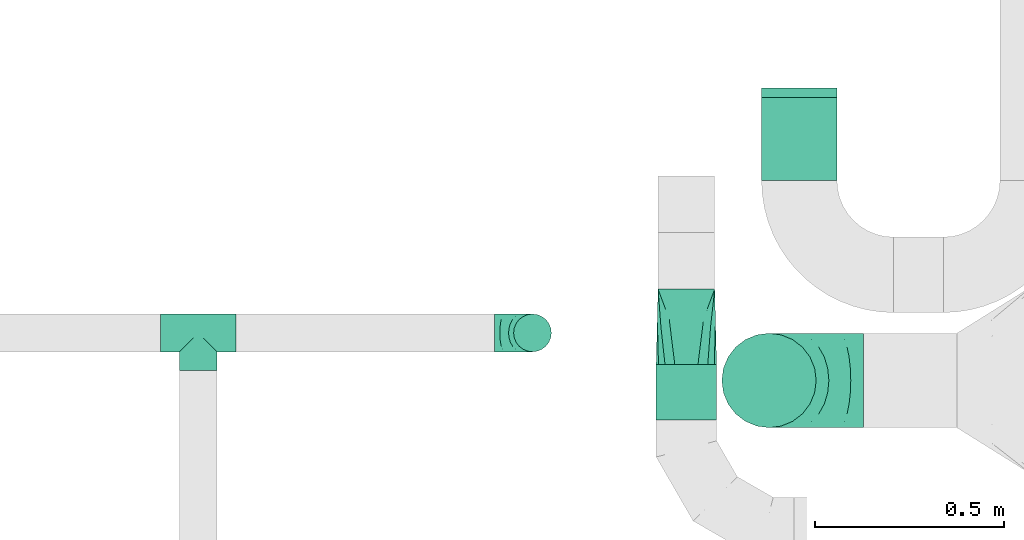
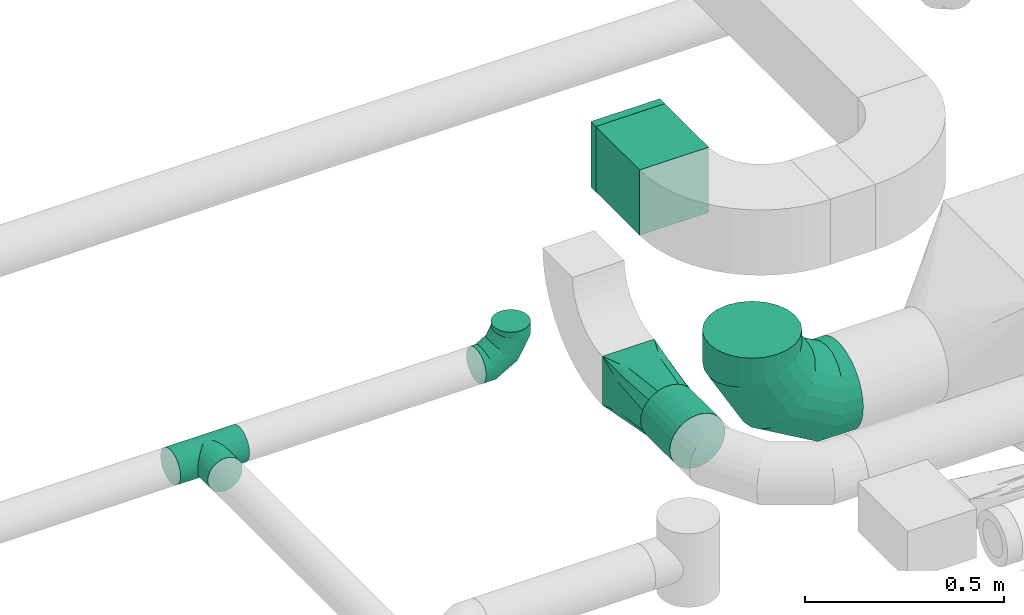
# One storey, part 70 of 92: 5 flow fittings, 2 flow segments.
"""IFC2X3 building model written with IfcOpenShell, lengths in millimetres."""

from ifc_helpers import new_model, entity, si_unit, converted_unit, derived_unit, direction, frame, origin, origin_2d_with_axis, place, context, subcontext, project, spatial, rectangle, circle, extrude, faceted_brep, source, transform, mapped, material, type_object, type_shapes, element, save


model = new_model("IFC2X3")

# Units and contexts
model_context = context("Model", 3, precision=0.01, world=origin(), true_north=direction((6.12303176911189e-17, 1.0)))
body_context = subcontext(model_context, "Body", "Model", "MODEL_VIEW")
ifc_project = project(units=[si_unit("LENGTHUNIT", "METRE", prefix="MILLI"), si_unit("AREAUNIT", "SQUARE_METRE"), si_unit("VOLUMEUNIT", "CUBIC_METRE"), converted_unit("PLANEANGLEUNIT", "DEGREE", entity("IfcRatioMeasure", 0.0174532925199433), si_unit("PLANEANGLEUNIT", "RADIAN"), dimensions=[0, 0, 0, 0, 0, 0, 0]), si_unit("MASSUNIT", "GRAM", prefix="KILO"), derived_unit("MASSDENSITYUNIT", [(si_unit("MASSUNIT", "GRAM", prefix="KILO"), 1), (si_unit("LENGTHUNIT", "METRE"), -3)]), derived_unit("MOMENTOFINERTIAUNIT", [(si_unit("LENGTHUNIT", "METRE"), 4)]), si_unit("TIMEUNIT", "SECOND"), si_unit("FREQUENCYUNIT", "HERTZ"), si_unit("THERMODYNAMICTEMPERATUREUNIT", "DEGREE_CELSIUS"), derived_unit("THERMALTRANSMITTANCEUNIT", [(si_unit("MASSUNIT", "GRAM", prefix="KILO"), 1), (si_unit("THERMODYNAMICTEMPERATUREUNIT", "KELVIN"), -1), (si_unit("TIMEUNIT", "SECOND"), -3)]), derived_unit("VOLUMETRICFLOWRATEUNIT", [(si_unit("LENGTHUNIT", "METRE"), 3), (si_unit("TIMEUNIT", "SECOND"), -1)]), derived_unit("MASSFLOWRATEUNIT", [(si_unit("MASSUNIT", "GRAM", prefix="KILO"), 1), (si_unit("TIMEUNIT", "SECOND"), -1)]), derived_unit("ROTATIONALFREQUENCYUNIT", [(si_unit("TIMEUNIT", "SECOND"), -1)]), si_unit("ELECTRICCURRENTUNIT", "AMPERE"), si_unit("ELECTRICVOLTAGEUNIT", "VOLT"), si_unit("POWERUNIT", "WATT"), si_unit("FORCEUNIT", "NEWTON", prefix="KILO"), si_unit("ILLUMINANCEUNIT", "LUX"), si_unit("LUMINOUSFLUXUNIT", "LUMEN"), si_unit("LUMINOUSINTENSITYUNIT", "CANDELA"), derived_unit("USERDEFINED", [(si_unit("MASSUNIT", "GRAM", prefix="KILO"), -1), (si_unit("LENGTHUNIT", "METRE"), -2), (si_unit("TIMEUNIT", "SECOND"), 3), (si_unit("LUMINOUSFLUXUNIT", "LUMEN"), 1)]), derived_unit("LINEARVELOCITYUNIT", [(si_unit("LENGTHUNIT", "METRE"), 1), (si_unit("TIMEUNIT", "SECOND"), -1)]), si_unit("PRESSUREUNIT", "PASCAL"), derived_unit("USERDEFINED", [(si_unit("LENGTHUNIT", "METRE"), -2), (si_unit("MASSUNIT", "GRAM", prefix="KILO"), 1), (si_unit("TIMEUNIT", "SECOND"), -2)]), derived_unit("LINEARFORCEUNIT", [(si_unit("MASSUNIT", "GRAM", prefix="KILO"), 1), (si_unit("LENGTHUNIT", "METRE"), 1), (si_unit("TIMEUNIT", "SECOND"), -2), (si_unit("LENGTHUNIT", "METRE"), -1)]), derived_unit("PLANARFORCEUNIT", [(si_unit("MASSUNIT", "GRAM", prefix="KILO"), 1), (si_unit("LENGTHUNIT", "METRE"), 1), (si_unit("TIMEUNIT", "SECOND"), -2), (si_unit("LENGTHUNIT", "METRE"), -2)])], contexts=[model_context])

# Site, building, storey
site_placement = place(None, origin())
site = spatial("IfcSite", under=ifc_project, at=site_placement, CompositionType="ELEMENT")
building_placement = place(site_placement, origin())
building = spatial("IfcBuilding", under=site, at=building_placement, CompositionType="ELEMENT")
storey_placement = place(building_placement, frame((0.0, 0.0, 4200.0)))
storey = spatial("IfcBuildingStorey", under=building, at=storey_placement, CompositionType="ELEMENT", Elevation=4200.0)

# Flow segments
duct_segment_type_1 = type_object("IfcDuctSegmentType", PredefinedType="NOTDEFINED")
flow_segment_1_placement = place(storey_placement, frame((59449.99, 13023.45, 3224.59)))
element("IfcFlowSegment", 1, at=flow_segment_1_placement, inside=storey, type_object=duct_segment_type_1, context=body_context, shape_type="SweptSolid", body=[
    extrude(rectangle(XDim=220.000000000004, YDim=199.999999999998, at=origin_2d_with_axis()), frame((100.0, 110.0, 0.0), z_axis=(0.0, 0.0, 1.0), x_axis=(0.0, 1.0, 0.0)), (0.0, 0.0, 1.0), 200.0),
])
duct_segment_type_2 = type_object("IfcDuctSegmentType", PredefinedType="NOTDEFINED")
flow_segment_2_placement = place(storey_placement, frame((59169.54, 12388.83, 2968.4)))
element("IfcFlowSegment", 2, at=flow_segment_2_placement, inside=storey, type_object=duct_segment_type_2, context=body_context, shape_type="SweptSolid", body=[
    extrude(circle(Radius=80.0, at=origin_2d_with_axis()), frame((81.6, 0.0, 81.6), z_axis=(0.0, 1.0, 0.0), x_axis=(-1.0, 0.0, 0.0)), (0.0, 0.0, 1.0), 146.751249421512),
])

# Flow fittings
ifc_material = material()
duct_fitting_type_1 = type_object("IfcDuctFittingType", PredefinedType="NOTDEFINED", material=ifc_material)
shared_shape_1 = source(origin(), body_context, "Body", "SweptSolid", [
    extrude(rectangle(XDim=24.9999999999999, YDim=200.0, at=origin_2d_with_axis()), frame((12.5, 0.0, -100.0)), (0.0, 0.0, 1.0), 200.0),
])
type_shapes(duct_fitting_type_1, [shared_shape_1])
flow_fitting_1_placement = place(storey_placement, frame((59549.99, 13243.45, 3324.59), z_axis=(0.0, 0.0, 1.0), x_axis=(0.0, 1.0, 0.0)))
element("IfcFlowFitting", 3, at=flow_fitting_1_placement, inside=storey, type_object=duct_fitting_type_1, material=ifc_material, context=body_context, shape_type="MappedRepresentation", body=[
    mapped(shared_shape_1, transform((0.0, 0.0, 0.0), scale=1.0)),
])
duct_fitting_type_2 = type_object("IfcDuctFittingType", PredefinedType="NOTDEFINED", material=ifc_material)
shared_shape_2 = source(origin(), body_context, "Body", "Brep", [
    faceted_brep([(-100.0, 0.0, -50.0), (-100.0, -12.94, -48.3), (-100.0, -25.0, -43.3), (-100.0, -35.36, -35.36), (-100.0, -43.3, -25.0), (-100.0, -48.3, -12.94), (-100.0, -50.0, 0.0), (-100.0, -48.3, 12.94), (-100.0, -43.3, 25.0), (-100.0, -35.36, 35.36), (-100.0, -25.0, 43.3), (-100.0, -12.94, 48.3), (-100.0, 0.0, 50.0), (-100.0, 12.94, 48.3), (-100.0, 25.0, 43.3), (-100.0, 35.36, 35.36), (-100.0, 43.3, 25.0), (-100.0, 48.3, 12.94), (-100.0, 50.0, 0.0), (-100.0, 48.3, -12.94), (-100.0, 43.3, -25.0), (-100.0, 35.36, -35.36), (-100.0, 25.0, -43.3), (-100.0, 12.94, -48.3), (-76.67, 12.94, 48.3), (-79.9, 25.0, 43.3), (-73.21, 0.0, 50.0), (-82.68, 35.36, 35.36), (-86.15, 48.3, 12.94), (-86.6, 50.0, 0.0), (-84.81, 43.3, 25.0), (-84.81, 43.3, -25.0), (-82.68, 35.36, -35.36), (-86.15, 48.3, -12.94), (-76.67, 12.94, -48.3), (-73.21, 0.0, -50.0), (-79.9, 25.0, -43.3), (-69.74, -12.94, -48.3), (-66.51, -25.0, -43.3), (-63.73, -35.36, -35.36), (-61.6, -43.3, -25.0), (-60.26, -48.3, -12.94), (-59.81, -50.0, 0.0), (-60.26, -48.3, 12.94), (-61.6, -43.3, 25.0), (-63.73, -35.36, 35.36), (-66.51, -25.0, 43.3), (-69.74, -12.94, 48.3), (-36.27, 36.27, 48.3), (-45.1, 45.1, 43.3), (-26.79, 26.79, 50.0), (-52.68, 52.68, 35.36), (-58.49, 58.49, 25.0), (-62.15, 62.15, 12.94), (-63.4, 63.4, 0.0), (-62.15, 62.15, -12.94), (-58.49, 58.49, -25.0), (-52.68, 52.68, -35.36), (-36.27, 36.27, -48.3), (-26.79, 26.79, -50.0), (-45.1, 45.1, -43.3), (-17.32, 17.32, -48.3), (-8.49, 8.49, -43.3), (-0.91, 0.91, -35.36), (4.9, -4.9, -25.0), (8.56, -8.56, -12.94), (9.81, -9.81, 0.0), (8.56, -8.56, 12.94), (4.9, -4.9, 25.0), (-0.91, 0.91, 35.36), (-8.49, 8.49, 43.3), (-17.32, 17.32, 48.3), (-12.94, 76.67, 48.3), (-25.0, 79.9, 43.3), (0.0, 73.21, 50.0), (-35.36, 82.68, 35.36), (-43.3, 84.81, 25.0), (-48.3, 86.15, 12.94), (-50.0, 86.6, 0.0), (-48.3, 86.15, -12.94), (-43.3, 84.81, -25.0), (-35.36, 82.68, -35.36), (-12.94, 76.67, -48.3), (0.0, 73.21, -50.0), (-25.0, 79.9, -43.3), (12.94, 69.74, -48.3), (25.0, 66.51, -43.3), (35.36, 63.73, -35.36), (43.3, 61.6, -25.0), (48.3, 60.26, -12.94), (50.0, 59.81, 0.0), (48.3, 60.26, 12.94), (43.3, 61.6, 25.0), (35.36, 63.73, 35.36), (25.0, 66.51, 43.3), (12.94, 69.74, 48.3), (-12.94, 100.0, -48.3), (-25.0, 100.0, -43.3), (-35.36, 100.0, -35.36), (-43.3, 100.0, -25.0), (-48.3, 100.0, -12.94), (-50.0, 100.0, 0.0), (-48.3, 100.0, 12.94), (-43.3, 100.0, 25.0), (-35.36, 100.0, 35.36), (-25.0, 100.0, 43.3), (-12.94, 100.0, 48.3), (0.0, 100.0, 50.0), (12.94, 100.0, 48.3), (25.0, 100.0, 43.3), (35.36, 100.0, 35.36), (43.3, 100.0, 25.0), (48.3, 100.0, 12.94), (50.0, 100.0, 0.0), (48.3, 100.0, -12.94), (43.3, 100.0, -25.0), (35.36, 100.0, -35.36), (25.0, 100.0, -43.3), (12.94, 100.0, -48.3), (0.0, 100.0, -50.0)], [[[0, 1, 2, 3, 4, 5, 6, 7, 8, 9, 10, 11, 12, 13, 14, 15, 16, 17, 18, 19, 20, 21, 22, 23]], [[24, 25, 14, 13]], [[26, 24, 13, 12]], [[14, 25, 27, 15]], [[28, 29, 18, 17]], [[30, 28, 17, 16]], [[15, 27, 30, 16]], [[20, 31, 32, 21]], [[33, 31, 20, 19]], [[18, 29, 33, 19]], [[34, 35, 0, 23]], [[36, 34, 23, 22]], [[32, 36, 22, 21]], [[2, 1, 37, 38]], [[3, 2, 38, 39]], [[0, 35, 37, 1]], [[5, 4, 40, 41]], [[6, 5, 41, 42]], [[3, 39, 40, 4]], [[6, 42, 43, 7]], [[7, 43, 44, 8]], [[8, 44, 45, 9]], [[10, 46, 47, 11]], [[11, 47, 26, 12]], [[10, 9, 45, 46]], [[48, 49, 25, 24]], [[50, 48, 24, 26]], [[27, 25, 49, 51]], [[52, 53, 28, 30]], [[51, 52, 30, 27]], [[29, 28, 53, 54]], [[55, 56, 31, 33]], [[54, 55, 33, 29]], [[57, 32, 31, 56]], [[58, 59, 35, 34]], [[60, 58, 34, 36]], [[57, 60, 36, 32]], [[37, 35, 59, 61]], [[38, 37, 61, 62]], [[39, 38, 62, 63]], [[41, 40, 64, 65]], [[42, 41, 65, 66]], [[63, 64, 40, 39]], [[43, 42, 66, 67]], [[44, 43, 67, 68]], [[68, 69, 45, 44]], [[46, 45, 69, 70]], [[47, 46, 70, 71]], [[26, 47, 71, 50]], [[72, 73, 49, 48]], [[74, 72, 48, 50]], [[51, 49, 73, 75]], [[76, 77, 53, 52]], [[75, 76, 52, 51]], [[54, 53, 77, 78]], [[79, 80, 56, 55]], [[78, 79, 55, 54]], [[81, 57, 56, 80]], [[82, 83, 59, 58]], [[84, 82, 58, 60]], [[81, 84, 60, 57]], [[61, 59, 83, 85]], [[62, 61, 85, 86]], [[63, 62, 86, 87]], [[65, 64, 88, 89]], [[66, 65, 89, 90]], [[87, 88, 64, 63]], [[67, 66, 90, 91]], [[68, 67, 91, 92]], [[92, 93, 69, 68]], [[70, 69, 93, 94]], [[71, 70, 94, 95]], [[50, 71, 95, 74]], [[96, 97, 98, 99, 100, 101, 102, 103, 104, 105, 106, 107, 108, 109, 110, 111, 112, 113, 114, 115, 116, 117, 118, 119]], [[72, 74, 107, 106]], [[73, 72, 106, 105]], [[75, 73, 105, 104]], [[77, 76, 103, 102]], [[78, 77, 102, 101]], [[75, 104, 103, 76]], [[78, 101, 100, 79]], [[79, 100, 99, 80]], [[80, 99, 98, 81]], [[96, 119, 83, 82]], [[97, 96, 82, 84]], [[84, 81, 98, 97]], [[83, 119, 118, 85]], [[85, 118, 117, 86]], [[86, 117, 116, 87]], [[88, 115, 114, 89]], [[89, 114, 113, 90]], [[87, 116, 115, 88]], [[91, 90, 113, 112]], [[92, 91, 112, 111]], [[93, 92, 111, 110]], [[95, 94, 109, 108]], [[74, 95, 108, 107]], [[110, 109, 94, 93]]]),
])
type_shapes(duct_fitting_type_2, [shared_shape_2])
flow_fitting_2_placement = place(storey_placement, frame((58843.56, 12619.72, 3320.0), z_axis=(0.0, -1.0, 0.0), x_axis=(1.0, 0.0, 0.0)))
element("IfcFlowFitting", 4, at=flow_fitting_2_placement, inside=storey, type_object=duct_fitting_type_2, material=ifc_material, context=body_context, shape_type="MappedRepresentation", body=[
    mapped(shared_shape_2, transform((0.0, 0.0, 0.0), scale=1.0)),
])
duct_fitting_type_3 = type_object("IfcDuctFittingType", PredefinedType="NOTDEFINED", material=ifc_material)
shared_shape_3 = source(origin(), body_context, "Body", "Brep", [
    faceted_brep([(-250.0, 0.0, -125.0), (-250.0, -32.35, -120.74), (-250.0, -62.5, -108.25), (-250.0, -88.39, -88.39), (-250.0, -108.25, -62.5), (-250.0, -120.74, -32.35), (-250.0, -125.0, 0.0), (-250.0, -120.74, 32.35), (-250.0, -108.25, 62.5), (-250.0, -88.39, 88.39), (-250.0, -62.5, 108.25), (-250.0, -32.35, 120.74), (-250.0, 0.0, 125.0), (-250.0, 32.35, 120.74), (-250.0, 62.5, 108.25), (-250.0, 88.39, 88.39), (-250.0, 108.25, 62.5), (-250.0, 120.74, 32.35), (-250.0, 125.0, 0.0), (-250.0, 120.74, -32.35), (-250.0, 108.25, -62.5), (-250.0, 88.39, -88.39), (-250.0, 62.5, -108.25), (-250.0, 32.35, -120.74), (-191.68, 32.35, 120.74), (-199.76, 62.5, 108.25), (-183.01, 0.0, 125.0), (-206.7, 88.39, 88.39), (-215.37, 120.74, 32.35), (-216.51, 125.0, 0.0), (-212.02, 108.25, 62.5), (-212.02, 108.25, -62.5), (-206.7, 88.39, -88.39), (-215.37, 120.74, -32.35), (-191.68, 32.35, -120.74), (-183.01, 0.0, -125.0), (-199.76, 62.5, -108.25), (-174.34, -32.35, -120.74), (-166.27, -62.5, -108.25), (-159.33, -88.39, -88.39), (-154.01, -108.25, -62.5), (-150.66, -120.74, -32.35), (-149.52, -125.0, 0.0), (-150.66, -120.74, 32.35), (-154.01, -108.25, 62.5), (-159.33, -88.39, 88.39), (-166.27, -62.5, 108.25), (-174.34, -32.35, 120.74), (-90.67, 90.67, 120.74), (-112.74, 112.74, 108.25), (-66.99, 66.99, 125.0), (-131.69, 131.69, 88.39), (-146.23, 146.23, 62.5), (-155.38, 155.38, 32.35), (-158.49, 158.49, 0.0), (-155.38, 155.38, -32.35), (-146.23, 146.23, -62.5), (-131.69, 131.69, -88.39), (-90.67, 90.67, -120.74), (-66.99, 66.99, -125.0), (-112.74, 112.74, -108.25), (-43.3, 43.3, -120.74), (-21.23, 21.23, -108.25), (-2.28, 2.28, -88.39), (12.26, -12.26, -62.5), (21.4, -21.4, -32.35), (24.52, -24.52, 0.0), (21.4, -21.4, 32.35), (12.26, -12.26, 62.5), (-2.28, 2.28, 88.39), (-21.23, 21.23, 108.25), (-43.3, 43.3, 120.74), (-32.35, 191.68, 120.74), (-62.5, 199.76, 108.25), (0.0, 183.01, 125.0), (-88.39, 206.7, 88.39), (-108.25, 212.02, 62.5), (-120.74, 215.37, 32.35), (-125.0, 216.51, 0.0), (-120.74, 215.37, -32.35), (-108.25, 212.02, -62.5), (-88.39, 206.7, -88.39), (-32.35, 191.68, -120.74), (0.0, 183.01, -125.0), (-62.5, 199.76, -108.25), (32.35, 174.34, -120.74), (62.5, 166.27, -108.25), (88.39, 159.33, -88.39), (108.25, 154.01, -62.5), (120.74, 150.66, -32.35), (125.0, 149.52, 0.0), (120.74, 150.66, 32.35), (108.25, 154.01, 62.5), (88.39, 159.33, 88.39), (62.5, 166.27, 108.25), (32.35, 174.34, 120.74), (-32.35, 250.0, -120.74), (-62.5, 250.0, -108.25), (-88.39, 250.0, -88.39), (-108.25, 250.0, -62.5), (-120.74, 250.0, -32.35), (-125.0, 250.0, 0.0), (-120.74, 250.0, 32.35), (-108.25, 250.0, 62.5), (-88.39, 250.0, 88.39), (-62.5, 250.0, 108.25), (-32.35, 250.0, 120.74), (0.0, 250.0, 125.0), (32.35, 250.0, 120.74), (62.5, 250.0, 108.25), (88.39, 250.0, 88.39), (108.25, 250.0, 62.5), (120.74, 250.0, 32.35), (125.0, 250.0, 0.0), (120.74, 250.0, -32.35), (108.25, 250.0, -62.5), (88.39, 250.0, -88.39), (62.5, 250.0, -108.25), (32.35, 250.0, -120.74), (0.0, 250.0, -125.0)], [[[0, 1, 2, 3, 4, 5, 6, 7, 8, 9, 10, 11, 12, 13, 14, 15, 16, 17, 18, 19, 20, 21, 22, 23]], [[24, 25, 14, 13]], [[26, 24, 13, 12]], [[14, 25, 27, 15]], [[28, 29, 18, 17]], [[30, 28, 17, 16]], [[15, 27, 30, 16]], [[20, 31, 32, 21]], [[33, 31, 20, 19]], [[18, 29, 33, 19]], [[34, 35, 0, 23]], [[36, 34, 23, 22]], [[21, 32, 36, 22]], [[1, 0, 35, 37]], [[2, 1, 37, 38]], [[38, 39, 3, 2]], [[5, 4, 40, 41]], [[6, 5, 41, 42]], [[39, 40, 4, 3]], [[6, 42, 43, 7]], [[7, 43, 44, 8]], [[8, 44, 45, 9]], [[9, 45, 46, 10]], [[10, 46, 47, 11]], [[26, 12, 11, 47]], [[48, 49, 25, 24]], [[50, 48, 24, 26]], [[27, 25, 49, 51]], [[52, 53, 28, 30]], [[51, 52, 30, 27]], [[29, 28, 53, 54]], [[55, 56, 31, 33]], [[54, 55, 33, 29]], [[32, 31, 56, 57]], [[58, 59, 35, 34]], [[60, 58, 34, 36]], [[57, 60, 36, 32]], [[37, 35, 59, 61]], [[38, 37, 61, 62]], [[39, 38, 62, 63]], [[41, 40, 64, 65]], [[42, 41, 65, 66]], [[63, 64, 40, 39]], [[43, 42, 66, 67]], [[44, 43, 67, 68]], [[68, 69, 45, 44]], [[46, 45, 69, 70]], [[47, 46, 70, 71]], [[26, 47, 71, 50]], [[72, 73, 49, 48]], [[74, 72, 48, 50]], [[51, 49, 73, 75]], [[76, 77, 53, 52]], [[75, 76, 52, 51]], [[54, 53, 77, 78]], [[79, 80, 56, 55]], [[78, 79, 55, 54]], [[57, 56, 80, 81]], [[82, 83, 59, 58]], [[84, 82, 58, 60]], [[81, 84, 60, 57]], [[61, 59, 83, 85]], [[62, 61, 85, 86]], [[63, 62, 86, 87]], [[65, 64, 88, 89]], [[66, 65, 89, 90]], [[87, 88, 64, 63]], [[67, 66, 90, 91]], [[68, 67, 91, 92]], [[92, 93, 69, 68]], [[70, 69, 93, 94]], [[71, 70, 94, 95]], [[50, 71, 95, 74]], [[96, 97, 98, 99, 100, 101, 102, 103, 104, 105, 106, 107, 108, 109, 110, 111, 112, 113, 114, 115, 116, 117, 118, 119]], [[72, 74, 107, 106]], [[73, 72, 106, 105]], [[75, 73, 105, 104]], [[77, 76, 103, 102]], [[78, 77, 102, 101]], [[75, 104, 103, 76]], [[78, 101, 100, 79]], [[79, 100, 99, 80]], [[80, 99, 98, 81]], [[84, 97, 96, 82]], [[82, 96, 119, 83]], [[84, 81, 98, 97]], [[83, 119, 118, 85]], [[85, 118, 117, 86]], [[116, 87, 86, 117]], [[88, 115, 114, 89]], [[89, 114, 113, 90]], [[115, 88, 87, 116]], [[91, 90, 113, 112]], [[92, 91, 112, 111]], [[111, 110, 93, 92]], [[95, 94, 109, 108]], [[74, 95, 108, 107]], [[110, 109, 94, 93]]]),
])
type_shapes(duct_fitting_type_3, [shared_shape_3])
flow_fitting_3_placement = place(storey_placement, frame((59469.99, 12493.72, 3000.0), z_axis=(0.0, 1.0, 0.0), x_axis=(-1.0, 0.0, 0.0)))
element("IfcFlowFitting", 5, at=flow_fitting_3_placement, inside=storey, type_object=duct_fitting_type_3, material=ifc_material, context=body_context, shape_type="MappedRepresentation", body=[
    mapped(shared_shape_3, transform((0.0, 0.0, 0.0), scale=1.0)),
])
duct_fitting_type_4 = type_object("IfcDuctFittingType", PredefinedType="NOTDEFINED", material=ifc_material)
shared_shape_4 = source(origin(), body_context, "Body", "Brep", [
    faceted_brep([(6.73, -6.73, -49.54), (100.0, 0.0, -50.0), (100.0, -12.94, -48.3), (100.0, -25.0, -43.3), (19.94, -19.94, -45.85), (32.27, -32.27, -38.19), (100.0, -35.36, -35.36), (26.27, -26.27, -42.54), (0.0, 0.0, -50.0), (-6.73, -6.73, -49.54), (-100.0, 0.0, -50.0), (13.4, -13.4, -48.17), (37.8, -37.8, -32.73), (100.0, -43.3, -25.0), (46.54, -46.54, -18.28), (100.0, -48.3, -12.94), (49.1, -49.1, -9.45), (100.0, -50.0, 0.0), (42.66, -42.66, -26.08), (50.0, -50.0, 0.0), (-100.0, -50.0, 0.0), (-49.1, -49.1, -9.45), (-50.0, -50.0, 0.0), (49.1, -49.1, 9.45), (100.0, -48.3, 12.94), (46.54, -46.54, 18.28), (100.0, -43.3, 25.0), (37.8, -37.8, 32.73), (100.0, -35.36, 35.36), (-49.1, -49.1, 9.45), (42.66, -42.66, 26.08), (32.27, -32.27, 38.19), (26.27, -26.27, 42.54), (100.0, -25.0, 43.3), (19.94, -19.94, 45.85), (100.0, -12.94, 48.3), (6.73, -6.73, 49.54), (100.0, 0.0, 50.0), (13.4, -13.4, 48.17), (0.0, 0.0, 50.0), (-6.73, -6.73, 49.54), (-100.0, 0.0, 50.0), (12.94, -100.0, -48.3), (25.0, -100.0, -43.3), (35.36, -100.0, -35.36), (43.3, -100.0, -25.0), (48.3, -100.0, -12.94), (50.0, -100.0, 0.0), (48.3, -100.0, 12.94), (43.3, -100.0, 25.0), (35.36, -100.0, 35.36), (25.0, -100.0, 43.3), (12.94, -100.0, 48.3), (0.0, -100.0, 50.0), (-12.94, -100.0, 48.3), (-25.0, -100.0, 43.3), (-35.36, -100.0, 35.36), (-43.3, -100.0, 25.0), (-48.3, -100.0, 12.94), (-50.0, -100.0, 0.0), (-48.3, -100.0, -12.94), (-43.3, -100.0, -25.0), (-35.36, -100.0, -35.36), (-25.0, -100.0, -43.3), (-12.94, -100.0, -48.3), (0.0, -100.0, -50.0), (-19.94, -19.94, -45.85), (-32.27, -32.27, -38.19), (-26.27, -26.27, -42.54), (-13.4, -13.4, -48.17), (-37.8, -37.8, -32.73), (-46.54, -46.54, -18.28), (-42.66, -42.66, -26.08), (-46.54, -46.54, 18.28), (-37.8, -37.8, 32.73), (-42.66, -42.66, 26.08), (-32.27, -32.27, 38.19), (-26.27, -26.27, 42.54), (-19.94, -19.94, 45.85), (-13.4, -13.4, 48.17), (-100.0, -12.94, -48.3), (-100.0, -25.0, -43.3), (-100.0, -35.36, -35.36), (-100.0, -43.3, -25.0), (-100.0, -48.3, -12.94), (-100.0, -48.3, 12.94), (-100.0, -43.3, 25.0), (-100.0, -35.36, 35.36), (-100.0, -25.0, 43.3), (-100.0, -12.94, 48.3), (-100.0, 12.94, 48.3), (-100.0, 25.0, 43.3), (-100.0, 35.36, 35.36), (-100.0, 43.3, 25.0), (-100.0, 48.3, 12.94), (-100.0, 50.0, 0.0), (-100.0, 48.3, -12.94), (-100.0, 43.3, -25.0), (-100.0, 35.36, -35.36), (-100.0, 25.0, -43.3), (-100.0, 12.94, -48.3), (100.0, 12.94, -48.3), (100.0, 25.0, -43.3), (100.0, 35.36, -35.36), (100.0, 43.3, -25.0), (100.0, 48.3, -12.94), (100.0, 50.0, 0.0), (100.0, 48.3, 12.94), (100.0, 43.3, 25.0), (100.0, 35.36, 35.36), (100.0, 25.0, 43.3), (100.0, 12.94, 48.3)], [[[0, 1, 2]], [[2, 3, 4]], [[5, 3, 6]], [[5, 7, 3]], [[0, 8, 1]], [[8, 9, 10]], [[4, 11, 2]], [[7, 4, 3]], [[0, 2, 11]], [[12, 6, 13]], [[14, 13, 15]], [[16, 15, 17]], [[18, 12, 13]], [[16, 14, 15]], [[19, 16, 17]], [[20, 21, 22]], [[18, 13, 14]], [[6, 12, 5]], [[23, 17, 24]], [[25, 24, 26]], [[27, 26, 28]], [[23, 19, 17]], [[22, 29, 20]], [[30, 25, 26]], [[27, 30, 26]], [[23, 24, 25]], [[28, 31, 27]], [[32, 31, 33]], [[33, 31, 28]], [[34, 33, 35]], [[36, 35, 37]], [[34, 32, 33]], [[36, 38, 35]], [[39, 36, 37]], [[40, 39, 41]], [[34, 35, 38]], [[42, 43, 44, 45, 46, 47, 48, 49, 50, 51, 52, 53, 54, 55, 56, 57, 58, 59, 60, 61, 62, 63, 64, 65]], [[36, 53, 52]], [[52, 51, 34]], [[31, 51, 50]], [[31, 32, 51]], [[36, 39, 53]], [[34, 38, 52]], [[32, 34, 51]], [[36, 52, 38]], [[27, 50, 49]], [[25, 49, 48]], [[23, 48, 47]], [[30, 27, 49]], [[23, 25, 48]], [[19, 23, 47]], [[30, 49, 25]], [[50, 27, 31]], [[47, 46, 16]], [[45, 44, 12]], [[46, 45, 14]], [[16, 19, 47]], [[18, 14, 45]], [[12, 18, 45]], [[16, 46, 14]], [[44, 5, 12]], [[7, 5, 43]], [[43, 5, 44]], [[4, 43, 42]], [[0, 42, 65]], [[4, 7, 43]], [[0, 11, 42]], [[8, 0, 65]], [[4, 42, 11]], [[9, 65, 64]], [[64, 63, 66]], [[67, 63, 62]], [[67, 68, 63]], [[9, 8, 65]], [[66, 69, 64]], [[68, 66, 63]], [[9, 64, 69]], [[70, 62, 61]], [[71, 61, 60]], [[21, 60, 59]], [[72, 70, 61]], [[21, 71, 60]], [[22, 21, 59]], [[72, 61, 71]], [[62, 70, 67]], [[29, 59, 58]], [[73, 58, 57]], [[74, 57, 56]], [[29, 22, 59]], [[75, 73, 57]], [[74, 75, 57]], [[29, 58, 73]], [[56, 76, 74]], [[77, 76, 55]], [[55, 76, 56]], [[78, 55, 54]], [[40, 54, 53]], [[78, 77, 55]], [[40, 79, 54]], [[39, 40, 53]], [[78, 54, 79]], [[10, 80, 81, 82, 83, 84, 20, 85, 86, 87, 88, 89, 41, 90, 91, 92, 93, 94, 95, 96, 97, 98, 99, 100]], [[101, 102, 103, 104, 105, 106, 107, 108, 109, 110, 111, 37, 35, 33, 28, 26, 24, 17, 15, 13, 6, 3, 2, 1]], [[39, 37, 111, 90, 41]], [[91, 90, 111, 110]], [[110, 109, 92, 91]], [[93, 92, 109, 108]], [[94, 93, 108, 107]], [[95, 94, 107, 106]], [[105, 104, 97, 96]], [[106, 105, 96, 95]], [[104, 103, 98, 97]], [[99, 98, 103, 102]], [[100, 99, 102, 101]], [[8, 10, 100, 101, 1]], [[69, 66, 80]], [[9, 69, 80]], [[10, 9, 80]], [[81, 68, 67]], [[81, 80, 66]], [[81, 67, 82]], [[68, 81, 66]], [[70, 72, 83]], [[71, 21, 84]], [[72, 71, 83]], [[82, 70, 83]], [[21, 20, 84]], [[84, 83, 71]], [[70, 82, 67]], [[29, 73, 85]], [[75, 74, 86]], [[73, 75, 86]], [[85, 20, 29]], [[73, 86, 85]], [[74, 87, 86]], [[74, 76, 87]], [[78, 79, 89]], [[79, 40, 89]], [[76, 77, 88]], [[78, 88, 77]], [[78, 89, 88]], [[40, 41, 89]], [[76, 88, 87]]]),
])
type_shapes(duct_fitting_type_4, [shared_shape_4])
flow_fitting_4_placement = place(storey_placement, frame((57958.56, 12619.72, 3320.0)))
element("IfcFlowFitting", 6, at=flow_fitting_4_placement, inside=storey, type_object=duct_fitting_type_4, material=ifc_material, context=body_context, shape_type="MappedRepresentation", body=[
    mapped(shared_shape_4, transform((0.0, 0.0, 0.0), scale=1.0)),
])
duct_fitting_type_5 = type_object("IfcDuctFittingType", PredefinedType="NOTDEFINED", material=ifc_material)
shared_shape_5 = source(origin(), body_context, "Body", "Brep", [
    faceted_brep([(200.0, 30.61, 73.91), (200.0, 22.87, 75.45), (200.0, 15.12, 76.99), (200.0, 11.34, 77.74), (200.0, 7.56, 78.5), (200.0, 0.0, 80.0), (200.0, -7.56, 78.5), (200.0, -15.12, 76.99), (200.0, -18.99, 76.22), (200.0, -22.87, 75.45), (200.0, -30.61, 73.91), (200.0, -37.1, 69.57), (200.0, -43.59, 65.24), (200.0, -50.08, 60.9), (200.0, -56.57, 56.57), (200.0, -60.9, 50.08), (200.0, -65.24, 43.59), (200.0, -69.57, 37.1), (200.0, -73.91, 30.61), (200.0, -75.45, 22.87), (200.0, -76.99, 15.12), (200.0, -77.74, 11.34), (200.0, -78.5, 7.56), (200.0, -80.0, 0.0), (200.0, -78.5, -7.56), (200.0, -76.99, -15.12), (200.0, -76.22, -18.99), (200.0, -75.45, -22.87), (200.0, -73.91, -30.61), (200.0, -69.57, -37.1), (200.0, -65.24, -43.59), (200.0, -60.9, -50.08), (200.0, -56.57, -56.57), (200.0, -50.08, -60.9), (200.0, -43.59, -65.24), (200.0, -37.1, -69.57), (200.0, -30.61, -73.91), (200.0, -22.87, -75.45), (200.0, -15.12, -76.99), (200.0, -11.34, -77.74), (200.0, -7.56, -78.5), (200.0, 0.0, -80.0), (200.0, 7.56, -78.5), (200.0, 15.12, -76.99), (200.0, 18.99, -76.22), (200.0, 22.87, -75.45), (200.0, 30.61, -73.91), (200.0, 37.1, -69.57), (200.0, 43.59, -65.24), (200.0, 50.08, -60.9), (200.0, 56.57, -56.57), (200.0, 60.9, -50.08), (200.0, 65.24, -43.59), (200.0, 69.57, -37.1), (200.0, 73.91, -30.61), (200.0, 75.45, -22.87), (200.0, 76.99, -15.12), (200.0, 77.74, -11.34), (200.0, 78.5, -7.56), (200.0, 80.0, 0.0), (200.0, 78.5, 7.56), (200.0, 76.99, 15.12), (200.0, 76.22, 18.99), (200.0, 75.45, 22.87), (200.0, 73.91, 30.61), (200.0, 69.57, 37.1), (200.0, 65.24, 43.59), (200.0, 60.9, 50.08), (200.0, 56.57, 56.57), (200.0, 50.08, 60.9), (200.0, 43.59, 65.24), (200.0, 37.1, 69.57), (0.0, -75.0, 75.0), (0.0, 75.0, 75.0), (0.0, 75.0, -75.0), (0.0, -75.0, -75.0), (52.06, -55.48, 76.3), (78.09, -45.72, 76.95), (176.03, -8.99, 79.4), (152.06, -17.98, 78.8), (128.09, -26.97, 78.2), (104.11, -35.96, 77.6), (100.0, -67.44, 64.02), (78.09, -76.95, 45.72), (104.11, -77.6, 35.96), (128.09, -78.2, 26.97), (152.06, -78.8, 17.98), (164.04, -79.1, 13.48), (176.03, -79.4, 8.99), (26.03, -75.65, 65.24), (52.06, -76.3, 55.48), (26.03, -65.24, 75.65), (26.03, -75.65, -65.24), (52.06, -76.3, -55.48), (78.09, -76.95, -45.72), (104.11, -77.6, -35.96), (128.09, -78.2, -26.97), (152.06, -78.8, -17.98), (176.03, -79.4, -8.99), (100.0, -64.02, -67.44), (78.09, -45.72, -76.95), (104.11, -35.96, -77.6), (128.09, -26.97, -78.2), (152.06, -17.98, -78.8), (164.04, -13.48, -79.1), (176.03, -8.99, -79.4), (26.03, -65.24, -75.65), (52.06, -55.48, -76.3), (26.03, 65.24, -75.65), (52.06, 55.48, -76.3), (78.09, 45.72, -76.95), (104.11, 35.96, -77.6), (128.09, 26.97, -78.2), (152.06, 17.98, -78.8), (176.03, 8.99, -79.4), (100.0, 67.44, -64.02), (78.09, 76.95, -45.72), (104.11, 77.6, -35.96), (128.09, 78.2, -26.97), (152.06, 78.8, -17.98), (164.04, 79.1, -13.48), (176.03, 79.4, -8.99), (26.03, 75.65, -65.24), (52.06, 76.3, -55.48), (26.03, 75.65, 65.24), (52.06, 76.3, 55.48), (78.09, 76.95, 45.72), (104.11, 77.6, 35.96), (128.09, 78.2, 26.97), (152.06, 78.8, 17.98), (176.03, 79.4, 8.99), (100.0, 64.02, 67.44), (78.09, 45.72, 76.95), (104.11, 35.96, 77.6), (128.09, 26.97, 78.2), (152.06, 17.98, 78.8), (164.04, 13.48, 79.1), (176.03, 8.99, 79.4), (26.03, 65.24, 75.65), (52.06, 55.48, 76.3)], [[[0, 1, 2, 3, 4, 5, 6, 7, 8, 9, 10, 11, 12, 13, 14, 15, 16, 17, 18, 19, 20, 21, 22, 23, 24, 25, 26, 27, 28, 29, 30, 31, 32, 33, 34, 35, 36, 37, 38, 39, 40, 41, 42, 43, 44, 45, 46, 47, 48, 49, 50, 51, 52, 53, 54, 55, 56, 57, 58, 59, 60, 61, 62, 63, 64, 65, 66, 67, 68, 69, 70, 71]], [[72, 73, 74, 75]], [[76, 12, 77]], [[12, 11, 10, 77]], [[78, 79, 80, 81, 77, 10, 9, 8, 7, 6, 5]], [[13, 82, 14]], [[20, 19, 18, 83, 84, 85, 86, 87, 88, 23, 22, 21]], [[82, 72, 89]], [[82, 15, 14]], [[83, 16, 90]], [[91, 72, 82]], [[18, 17, 16, 83]], [[90, 16, 15]], [[15, 82, 89]], [[90, 15, 89]], [[76, 13, 12]], [[13, 76, 91]], [[82, 13, 91]], [[88, 87, 86, 85, 84, 83, 90, 89, 72, 75, 92, 93, 94, 95, 96, 97, 98, 23]], [[93, 30, 94]], [[30, 29, 28, 94]], [[98, 97, 96, 95, 94, 28, 27, 26, 25, 24, 23]], [[31, 99, 32]], [[38, 37, 36, 100, 101, 102, 103, 104, 105, 41, 40, 39]], [[99, 75, 106]], [[99, 33, 32]], [[100, 34, 107]], [[92, 75, 99]], [[36, 35, 34, 100]], [[107, 34, 33]], [[33, 99, 106]], [[107, 33, 106]], [[93, 31, 30]], [[31, 93, 92]], [[99, 31, 92]], [[105, 104, 103, 102, 101, 100, 107, 106, 75, 74, 108, 109, 110, 111, 112, 113, 114, 41]], [[109, 48, 110]], [[48, 47, 46, 110]], [[114, 113, 112, 111, 110, 46, 45, 44, 43, 42, 41]], [[49, 115, 50]], [[56, 55, 54, 116, 117, 118, 119, 120, 121, 59, 58, 57]], [[115, 74, 122]], [[115, 51, 50]], [[116, 52, 123]], [[108, 74, 115]], [[54, 53, 52, 116]], [[123, 52, 51]], [[51, 115, 122]], [[123, 51, 122]], [[109, 49, 48]], [[49, 109, 108]], [[115, 49, 108]], [[74, 73, 124, 125, 126, 127, 128, 129, 130, 59, 121, 120, 119, 118, 117, 116, 123, 122]], [[125, 66, 126]], [[66, 65, 64, 126]], [[130, 129, 128, 127, 126, 64, 63, 62, 61, 60, 59]], [[67, 131, 68]], [[2, 1, 0, 132, 133, 134, 135, 136, 137, 5, 4, 3]], [[131, 73, 138]], [[131, 69, 68]], [[132, 70, 139]], [[124, 73, 131]], [[0, 71, 70, 132]], [[139, 70, 69]], [[69, 131, 138]], [[139, 69, 138]], [[125, 67, 66]], [[67, 125, 124]], [[131, 67, 124]], [[73, 72, 91, 76, 77, 81, 80, 79, 78, 5, 137, 136, 135, 134, 133, 132, 139, 138]]]),
])
type_shapes(duct_fitting_type_5, [shared_shape_5])
flow_fitting_5_placement = place(storey_placement, frame((59251.13, 12735.58, 3050.0), z_axis=(1.83905089029899e-05, 0.0, 1.0), x_axis=(0.0, -1.0, 0.0)))
element("IfcFlowFitting", 7, at=flow_fitting_5_placement, inside=storey, type_object=duct_fitting_type_5, material=ifc_material, context=body_context, shape_type="MappedRepresentation", body=[
    mapped(shared_shape_5, transform((0.0, 0.0, 0.0), scale=1.0)),
])

save(model, "model.ifc")
